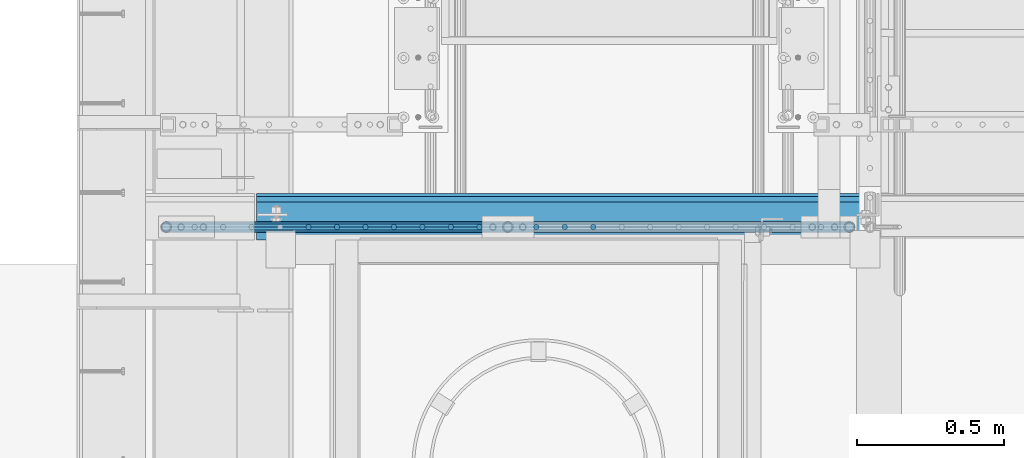
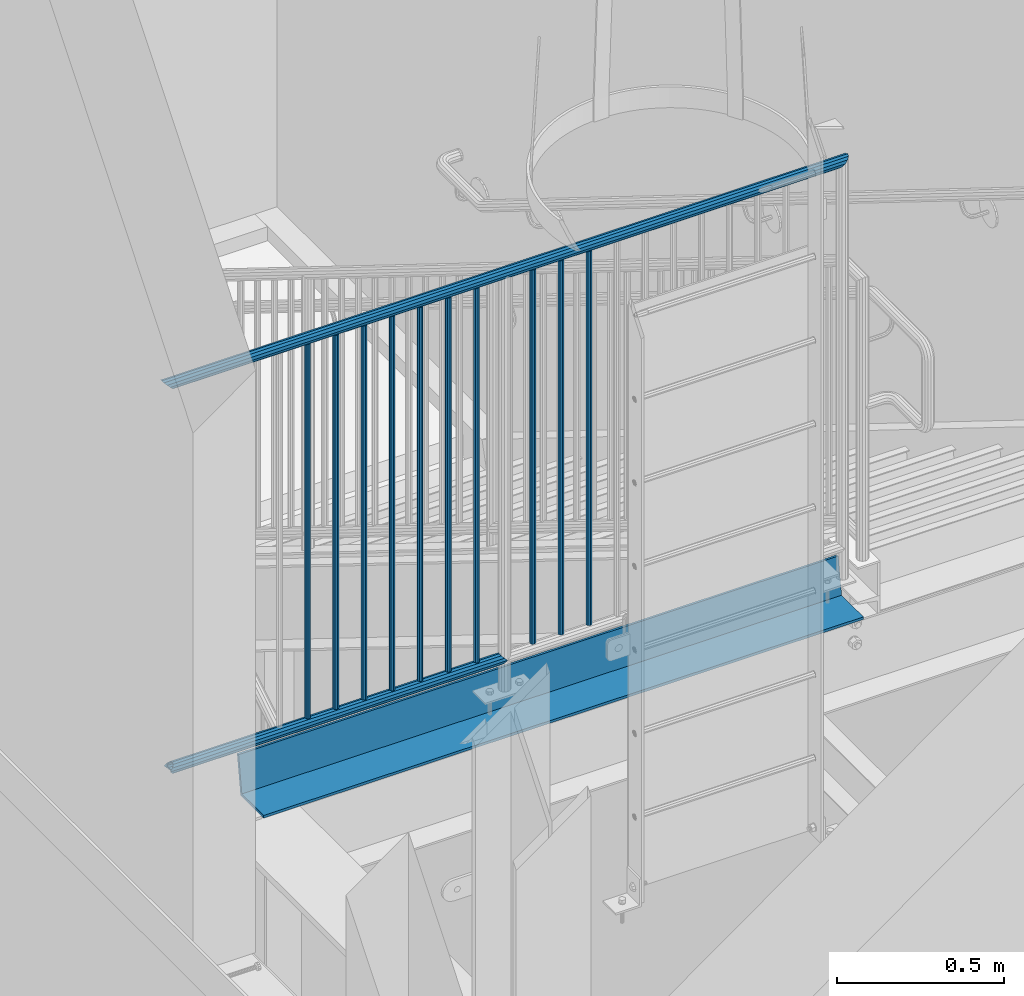
# One storey, part 1083 of 1763: 13 beams, 2 elements without a shape of their own.
"""IFC2X3 building model written with IfcOpenShell, lengths in millimetres."""

from ifc_helpers import new_model, si_unit, frame, origin_with_axes, place, context, subcontext, project, spatial, faceted_brep, material, type_object, element, aggregate, save


model = new_model("IFC2X3")

# Units and contexts
model_context = context("Model", 3, precision=1e-05, world=origin_with_axes())
body_context = subcontext(model_context, "Body", "Model", "MODEL_VIEW")
ifc_project = project(units=[si_unit("LENGTHUNIT", "METRE", prefix="MILLI"), si_unit("AREAUNIT", "SQUARE_METRE"), si_unit("VOLUMEUNIT", "CUBIC_METRE"), si_unit("MASSUNIT", "GRAM", prefix="KILO"), si_unit("TIMEUNIT", "SECOND"), si_unit("PLANEANGLEUNIT", "RADIAN"), si_unit("SOLIDANGLEUNIT", "STERADIAN"), si_unit("THERMODYNAMICTEMPERATUREUNIT", "DEGREE_CELSIUS"), si_unit("LUMINOUSINTENSITYUNIT", "LUMEN")], contexts=[model_context])

# Site, building, storey
site_placement = place(None, origin_with_axes())
site = spatial("IfcSite", under=ifc_project, at=site_placement, CompositionType="ELEMENT")
building_placement = place(site_placement, origin_with_axes())
building = spatial("IfcBuilding", under=site, at=building_placement, Name="Undefined", CompositionType="ELEMENT")
storey_placement = place(building_placement, origin_with_axes())
storey = spatial("IfcBuildingStorey", under=building, at=storey_placement, Name="Undefined", CompositionType="ELEMENT", Elevation=0.0)

# Assembly, beams
assembly_1_placement = place(storey_placement, origin_with_axes())
assembly_1 = element("IfcElementAssembly", 1, at=assembly_1_placement, inside=storey, Name="RAIL", AssemblyPlace="NOTDEFINED", PredefinedType="RIGID_FRAME")
ifc_material_1 = material(Name="STEEL/A513")
beam_type_1 = type_object("IfcBeamType", PredefinedType="NOTDEFINED")
beam_1_placement = place(assembly_1_placement, frame((-86514.9796871242, 31673.8000005342, 5454.64999991884), z_axis=(0.0, 0.0, 1.0), x_axis=(-1.0, 0.0, 0.0)))
beam_1 = element("IfcBeam", 2, at=beam_1_placement, type_object=beam_type_1, material=ifc_material_1, Name="RAIL", context=body_context, shape_type="Brep", body=[
    faceted_brep([(1148.75980258887, -9.52499999949214, 16.4977839420935), (1148.75980258887, -9.52500036633865, 11.4667120131071), (1148.26637405265, -7.68349999948987, 13.3082123799559), (1146.20758653089, 5.74800651520491e-10, 15.3670000000002), (1146.20758653089, 5.74800651520491e-10, 19.0500000000002), (1148.26637424916, 7.6835000005085, 13.3082123799559), (1148.75980258873, 9.52499963366063, 11.4667127468038), (1148.75980258873, 9.52500000051077, 16.4977839420935), (1165.25758657494, 19.0500000005159, 0.0), (1155.73258653076, 16.4977839426028, 9.52499999999964), (1155.73258653076, 16.4977839426028, -9.52499999999964), (1152.54301533551, 13.308212380467, 7.68350000000009), (1154.60180295554, 15.3670000005113, 0.0), (1152.54301533551, 13.308212380467, -7.68350000000009), (1148.75980258873, 9.52499963366063, -11.4667127468038), (1148.75980258873, 9.52500000051077, -16.4977839420935), (1148.26637424916, 7.6835000005085, -13.3082123799559), (1146.20758653089, 5.0931703299284e-10, -15.3670000000002), (1146.20758653089, 5.0931703299284e-10, -19.0500000000002), (1148.75980258887, -9.52500036633865, -11.4667120131071), (1148.75980258887, -9.52499999949214, -16.4977839420935), (1148.26637405265, -7.68349999948987, -13.3082123799559), (1165.25758653104, -19.050000366391, 0.0), (1155.73258653101, -16.4977839415842, -9.52499999999964), (1155.73258653101, -16.4977839415842, 9.52499999999964), (1152.54301460199, -13.3082123794447, -7.68350000000009), (1154.60180222205, -15.3669999994891, 0.0), (1152.54301460199, -13.3082123794447, 7.68350000000009), (9.52499999467545, -16.4977839420899, -9.52500000000009), (16.4977839367712, -9.52499999999418, -16.4977839420935), (0.0, 19.0500000000029, 0.0), (9.52499999467545, 16.4977839420899, -9.52500000000009), (9.52500000096188, 16.4977839420899, 9.52500000000009), (16.4977839430576, 9.52499999999418, 16.4977839420935), (19.0500000009633, 0.0, 19.0500000000002), (16.4977839367712, 9.52499999999418, -16.4977839420935), (19.0499999946769, 0.0, -19.0500000000002), (19.0499999946769, 0.0, -15.3670000000002), (16.4977839367712, -9.52500000031432, -11.4667123796353), (16.9912123747126, -7.68349999999919, -13.3082123799554), (16.9912123745453, 7.68349999999919, -13.3082123799554), (16.4977839367712, 9.52499999967404, -11.4667123802756), (12.7145715564911, 13.3082123799541, -7.68350000000009), (10.6557839364468, 15.3669999999984, 0.0), (12.7145715564911, 13.3082123799541, 7.68350000000009), (16.4977839367712, 9.52499999967404, 11.4667123802756), (16.9912123745453, 7.68349999999919, 13.3082123799554), (19.0499999946769, -3.20142135024071e-10, 15.3670000000002), (16.9912123747126, -7.68349999999919, 13.3082123799554), (16.4977839367712, -9.52500000031432, 11.4667123796353), (16.4977839430576, -9.52499999999418, 16.4977839420935), (9.52500000096188, -16.4977839420899, 9.52500000000009), (0.0, -19.0500000000029, 0.0), (12.7145715571314, -13.3082123799541, 7.68350000000009), (10.6557839370871, -15.3669999999984, 0.0), (12.7145715571314, -13.3082123799541, -7.68350000000009)], [[[0, 1, 2, 3, 4]], [[4, 3, 5, 6, 7]], [[8, 9, 10]], [[7, 6, 11, 12, 13, 14, 15, 10, 9]], [[16, 17, 18, 15, 14]], [[19, 20, 18, 17, 21]], [[22, 23, 24]], [[24, 23, 20, 19, 25, 26, 27, 1, 0]], [[28, 29, 20, 23]], [[30, 31, 32]], [[33, 34, 4, 7]], [[32, 33, 7, 9]], [[30, 32, 9, 8]], [[31, 30, 8, 10]], [[35, 31, 10, 15]], [[36, 35, 15, 18]], [[29, 36, 18, 20]], [[37, 36, 29, 38, 39]], [[40, 41, 35, 36, 37]], [[32, 31, 35, 41, 42, 43, 44, 45, 33]], [[33, 45, 46, 47, 34]], [[34, 47, 48, 49, 50]], [[34, 50, 0, 4]], [[50, 51, 24, 0]], [[51, 52, 22, 24]], [[52, 28, 23, 22]], [[51, 28, 52]], [[50, 49, 53, 54, 55, 38, 29, 28, 51]], [[55, 54, 26, 25]], [[21, 39, 38, 55, 25, 19]], [[37, 39, 21, 17]], [[40, 37, 17, 16]], [[42, 41, 40, 16, 14, 13]], [[43, 42, 13, 12]], [[44, 43, 12, 11]], [[5, 46, 45, 44, 11, 6]], [[47, 46, 5, 3]], [[48, 47, 3, 2]], [[53, 49, 48, 2, 1, 27]], [[54, 53, 27, 26]]]),
])
beam_2_placement = place(assembly_1_placement, frame((-87699.2872736982, 31673.7999995938, 6858.00000000992), z_axis=(0.0, 0.0, -1.0), x_axis=(1.0, 0.0, 0.0)))
beam_2 = element("IfcBeam", 3, at=beam_2_placement, type_object=beam_type_1, material=ifc_material_1, Name="RAIL", context=body_context, shape_type="Brep", body=[
    faceted_brep([(19.0500000000029, -15.3670000000855, 0.0), (26.7334999735467, -13.3082123799541, 7.68350000000009), (2341.881673235, -13.3082123809982, 7.68350000000009), (2349.56517323499, -15.3670000010461, 0.0), (32.3582123535016, -7.68349999999919, 13.3082123799554), (2336.25696085505, -7.68350000103965, 13.3082123799559), (34.4169999735459, 0.0, 15.3670000000002), (2334.19817323504, -1.03682396002114e-09, 15.3670000000002), (32.3582123535016, 7.68349999999919, 13.3082123799554), (2336.25696085511, 7.68349999896236, 13.3082123799559), (26.7334999735467, 13.3082123799541, 7.68350000000009), (2341.88167323508, 13.3082123789136, 7.68350000000009), (19.0500000000029, 15.3669999999146, 0.0), (2349.5651732351, 15.3669999989543, 0.0), (11.3664999735483, 13.3082123799541, -7.68350000000009), (2357.24867323508, 13.3082123789063, -7.68350000000009), (5.74178759359347, 7.68349999999919, -13.3082123799554), (2362.87338561502, 7.68349999894781, -13.3082123799559), (3.68299997354916, 0.0, -15.3670000000002), (2364.93217323505, -1.05137587524951e-09, -15.3670000000002), (5.74178759359347, -7.68349999999919, -13.3082123799554), (2362.87338561498, -7.68350000105056, -13.3082123799559), (11.3664999735483, -13.3082123799541, -7.68350000000009), (2357.24867323501, -13.3082123810054, -7.68350000000009), (19.0500000000029, -19.0500000000854, 0.0), (9.52499999467545, -16.4977839420899, -9.52500000000009), (2359.09017323499, -16.4977839431413, -9.52499999999964), (2349.56517323498, -19.050000001047, 0.0), (2.55221603145037, -9.52499999999418, -16.4977839420935), (2366.06295717711, -9.52500000105283, -16.4977839420935), (1.45519152283669e-11, 1.81898940354586e-12, -19.0499999999993), (2368.61517323504, -1.05137587524951e-09, -19.0500000000002), (2.55221603145037, 9.52499999999418, -16.4977839420935), (2366.06295717717, 9.52499999894644, -16.4977839420935), (9.52499999467545, 16.4977839420899, -9.52500000000009), (2359.0901732351, 16.4977839410458, -9.52499999999964), (19.0500000000029, 19.0499999999146, 0.0), (2349.56517323511, 19.0499999989552, 0.0), (28.574999973549, 16.4977839420899, 9.52500000000009), (2340.0401732351, 16.4977839410531, 9.52499999999964), (35.5477839156374, 9.52499999999418, 16.4977839420935), (2333.06738929298, 9.52499999896099, 16.4977839420935), (38.0999999735432, 0.0, 19.0500000000002), (2330.51517323505, -1.03682396002114e-09, 19.0500000000002), (35.5477839156374, -9.52499999999418, 16.4977839420935), (2333.06738929292, -9.52500000103828, 16.4977839420935), (28.574999973549, -16.4977839420899, 9.52500000000009), (2340.04017323499, -16.497783943134, 9.52499999999964)], [[[0, 1, 2, 3]], [[1, 4, 5, 2]], [[4, 6, 7, 5]], [[6, 8, 9, 7]], [[8, 10, 11, 9]], [[10, 12, 13, 11]], [[12, 14, 15, 13]], [[14, 16, 17, 15]], [[16, 18, 19, 17]], [[18, 20, 21, 19]], [[20, 22, 23, 21]], [[22, 0, 3, 23]], [[24, 25, 26, 27]], [[25, 28, 29, 26]], [[28, 30, 31, 29]], [[30, 32, 33, 31]], [[32, 34, 35, 33]], [[34, 36, 37, 35]], [[36, 38, 39, 37]], [[38, 40, 41, 39]], [[40, 42, 43, 41]], [[42, 44, 45, 43]], [[44, 46, 47, 45]], [[46, 24, 27, 47]], [[29, 31, 33, 35, 37, 39, 41, 43, 45, 47, 27, 26], [5, 7, 9, 11, 13, 15, 17, 19, 21, 23, 3, 2]], [[46, 44, 42, 40, 38, 36, 34, 32, 30, 28, 25, 24], [22, 20, 18, 16, 14, 12, 10, 8, 6, 4, 1, 0]]]),
])
ifc_material_2 = material(Name="STEEL/A36")
beam_type_2 = type_object("IfcBeamType", PredefinedType="NOTDEFINED")
beam_3_placement = place(assembly_1_placement, frame((-87194.7132792923, 31673.7999999813, 6857.99999997406), z_axis=(0.0, -1.0, 0.0), x_axis=(0.0, 0.0, -1.0)))
beam_3 = element("IfcBeam", 4, at=beam_3_placement, type_object=beam_type_2, material=ifc_material_2, Name="PICKET", context=body_context, shape_type="Brep", body=[
    faceted_brep([(19.0499999999092, -9.52500000000146, 0.0), (19.0499999999092, -6.73519209080405, -6.73519209079677), (1384.29999999477, -6.73519209082588, -6.73519209079677), (1384.29999999477, -9.52499999999418, 3.63797880709171e-12), (19.0499999999092, 0.0, -9.52499999999418), (1384.29999999477, -4.36557456851006e-11, -9.52500000000146), (19.0499999999092, 6.73519209080405, -6.73519209079677), (1384.29999999477, 6.73519209078222, -6.73519209080769), (19.0499999999092, 9.52500000000146, 0.0), (1384.29999999477, 9.52499999999418, -3.63797880709171e-12), (19.0499999999092, 6.73519209080405, 6.73519209079677), (1384.29999999477, 6.73519209082588, 6.73519209079677), (19.0499999999092, 0.0, 9.52499999999418), (1384.29999999477, 2.91038304567337e-11, 9.52500000000146), (19.0499999999092, -6.73519209080405, 6.73519209079677), (1384.29999999477, -6.73519209078222, 6.73519209080769)], [[[0, 1, 2, 3]], [[1, 4, 5, 2]], [[4, 6, 7, 5]], [[6, 8, 9, 7]], [[8, 10, 11, 9]], [[10, 12, 13, 11]], [[12, 14, 15, 13]], [[14, 0, 3, 15]], [[5, 7, 9, 11, 13, 15, 3, 2]], [[14, 12, 10, 8, 6, 4, 1, 0]]]),
])
beam_4_placement = place(assembly_1_placement, frame((-87097.6084804111, 31673.8000000588, 6857.99999996617), z_axis=(0.0, -1.0, 0.0), x_axis=(0.0, 0.0, -1.0)))
beam_4 = element("IfcBeam", 5, at=beam_4_placement, type_object=beam_type_2, material=ifc_material_2, Name="PICKET", context=body_context, shape_type="Brep", body=[
    faceted_brep([(19.0499999999092, -9.52500000000146, 0.0), (19.0499999999092, -6.73519209080405, -6.73519209079677), (1384.29999999477, -6.73519209082588, -6.73519209079677), (1384.29999999477, -9.52499999999418, 3.63797880709171e-12), (19.0499999999092, 0.0, -9.52499999999418), (1384.29999999477, -4.36557456851006e-11, -9.52500000000146), (19.0499999999092, 6.73519209080405, -6.73519209079677), (1384.29999999477, 6.73519209078222, -6.73519209080769), (19.0499999999092, 9.52500000000146, 0.0), (1384.29999999477, 9.52499999999418, -3.63797880709171e-12), (19.0499999999092, 6.73519209080405, 6.73519209079677), (1384.29999999477, 6.73519209082588, 6.73519209079677), (19.0499999999092, 0.0, 9.52499999999418), (1384.29999999477, 2.91038304567337e-11, 9.52500000000146), (19.0499999999092, -6.73519209080405, 6.73519209079677), (1384.29999999477, -6.73519209078222, 6.73519209080769)], [[[0, 1, 2, 3]], [[1, 4, 5, 2]], [[4, 6, 7, 5]], [[6, 8, 9, 7]], [[8, 10, 11, 9]], [[10, 12, 13, 11]], [[12, 14, 15, 13]], [[14, 0, 3, 15]], [[5, 7, 9, 11, 13, 15, 3, 2]], [[14, 12, 10, 8, 6, 4, 1, 0]]]),
])
beam_5_placement = place(assembly_1_placement, frame((-87000.5036815298, 31673.8000001364, 6857.99999995828), z_axis=(0.0, -1.0, 0.0), x_axis=(0.0, 0.0, -1.0)))
beam_5 = element("IfcBeam", 6, at=beam_5_placement, type_object=beam_type_2, material=ifc_material_2, Name="PICKET", context=body_context, shape_type="Brep", body=[
    faceted_brep([(19.0499999999092, -9.52500000000146, 0.0), (19.0499999999092, -6.73519209080405, -6.73519209079677), (1384.29999999477, -6.73519209082588, -6.73519209079677), (1384.29999999477, -9.52499999999418, 3.63797880709171e-12), (19.0499999999092, 0.0, -9.52499999999418), (1384.29999999477, -4.36557456851006e-11, -9.52500000000146), (19.0499999999092, 6.73519209080405, -6.73519209079677), (1384.29999999477, 6.73519209078222, -6.73519209080769), (19.0499999999092, 9.52500000000146, 0.0), (1384.29999999477, 9.52499999999418, -3.63797880709171e-12), (19.0499999999092, 6.73519209080405, 6.73519209079677), (1384.29999999477, 6.73519209082588, 6.73519209079677), (19.0499999999092, 0.0, 9.52499999999418), (1384.29999999477, 2.91038304567337e-11, 9.52500000000146), (19.0499999999092, -6.73519209080405, 6.73519209079677), (1384.29999999477, -6.73519209078222, 6.73519209080769)], [[[0, 1, 2, 3]], [[1, 4, 5, 2]], [[4, 6, 7, 5]], [[6, 8, 9, 7]], [[8, 10, 11, 9]], [[10, 12, 13, 11]], [[12, 14, 15, 13]], [[14, 0, 3, 15]], [[5, 7, 9, 11, 13, 15, 3, 2]], [[14, 12, 10, 8, 6, 4, 1, 0]]]),
])
beam_6_placement = place(assembly_1_placement, frame((-86903.3988826486, 31673.8000002139, 6857.99999995039), z_axis=(0.0, -1.0, 0.0), x_axis=(0.0, 0.0, -1.0)))
beam_6 = element("IfcBeam", 7, at=beam_6_placement, type_object=beam_type_2, material=ifc_material_2, Name="PICKET", context=body_context, shape_type="Brep", body=[
    faceted_brep([(19.0499999999092, -9.52500000000146, 0.0), (19.0499999999092, -6.73519209080405, -6.73519209079677), (1384.29999999477, -6.73519209082588, -6.73519209079677), (1384.29999999477, -9.52499999999418, 3.63797880709171e-12), (19.0499999999092, 0.0, -9.52499999999418), (1384.29999999477, -4.36557456851006e-11, -9.52500000000146), (19.0499999999092, 6.73519209080405, -6.73519209079677), (1384.29999999477, 6.73519209078222, -6.73519209080769), (19.0499999999092, 9.52500000000146, 0.0), (1384.29999999477, 9.52499999999418, -3.63797880709171e-12), (19.0499999999092, 6.73519209080405, 6.73519209079677), (1384.29999999477, 6.73519209082588, 6.73519209079677), (19.0499999999092, 0.0, 9.52499999999418), (1384.29999999477, 2.91038304567337e-11, 9.52500000000146), (19.0499999999092, -6.73519209080405, 6.73519209079677), (1384.29999999477, -6.73519209078222, 6.73519209080769)], [[[0, 1, 2, 3]], [[1, 4, 5, 2]], [[4, 6, 7, 5]], [[6, 8, 9, 7]], [[8, 10, 11, 9]], [[10, 12, 13, 11]], [[12, 14, 15, 13]], [[14, 0, 3, 15]], [[5, 7, 9, 11, 13, 15, 3, 2]], [[14, 12, 10, 8, 6, 4, 1, 0]]]),
])
beam_7_placement = place(assembly_1_placement, frame((-86806.2940837673, 31673.8000002914, 6857.9999999425), z_axis=(0.0, -1.0, 0.0), x_axis=(0.0, 0.0, -1.0)))
beam_7 = element("IfcBeam", 8, at=beam_7_placement, type_object=beam_type_2, material=ifc_material_2, Name="PICKET", context=body_context, shape_type="Brep", body=[
    faceted_brep([(19.0499999999092, -9.52500000000146, 0.0), (19.0499999999092, -6.73519209080405, -6.73519209079677), (1384.29999999477, -6.73519209082588, -6.73519209079677), (1384.29999999477, -9.52499999999418, 3.63797880709171e-12), (19.0499999999092, 0.0, -9.52499999999418), (1384.29999999477, -4.36557456851006e-11, -9.52500000000146), (19.0499999999092, 6.73519209080405, -6.73519209079677), (1384.29999999477, 6.73519209078222, -6.73519209080769), (19.0499999999092, 9.52500000000146, 0.0), (1384.29999999477, 9.52499999999418, -3.63797880709171e-12), (19.0499999999092, 6.73519209080405, 6.73519209079677), (1384.29999999477, 6.73519209082588, 6.73519209079677), (19.0499999999092, 0.0, 9.52499999999418), (1384.29999999477, 2.91038304567337e-11, 9.52500000000146), (19.0499999999092, -6.73519209080405, 6.73519209079677), (1384.29999999477, -6.73519209078222, 6.73519209080769)], [[[0, 1, 2, 3]], [[1, 4, 5, 2]], [[4, 6, 7, 5]], [[6, 8, 9, 7]], [[8, 10, 11, 9]], [[10, 12, 13, 11]], [[12, 14, 15, 13]], [[14, 0, 3, 15]], [[5, 7, 9, 11, 13, 15, 3, 2]], [[14, 12, 10, 8, 6, 4, 1, 0]]]),
])
beam_8_placement = place(assembly_1_placement, frame((-86709.1892848861, 31673.800000369, 6857.99999993461), z_axis=(0.0, -1.0, 0.0), x_axis=(0.0, 0.0, -1.0)))
beam_8 = element("IfcBeam", 9, at=beam_8_placement, type_object=beam_type_2, material=ifc_material_2, Name="PICKET", context=body_context, shape_type="Brep", body=[
    faceted_brep([(19.0499999999092, -9.52500000000146, 0.0), (19.0499999999092, -6.73519209080405, -6.73519209079677), (1384.29999999477, -6.73519209082588, -6.73519209079677), (1384.29999999477, -9.52499999999418, 3.63797880709171e-12), (19.0499999999092, 0.0, -9.52499999999418), (1384.29999999477, -4.36557456851006e-11, -9.52500000000146), (19.0499999999092, 6.73519209080405, -6.73519209079677), (1384.29999999477, 6.73519209078222, -6.73519209080769), (19.0499999999092, 9.52500000000146, 0.0), (1384.29999999477, 9.52499999999418, -3.63797880709171e-12), (19.0499999999092, 6.73519209080405, 6.73519209079677), (1384.29999999477, 6.73519209082588, 6.73519209079677), (19.0499999999092, 0.0, 9.52499999999418), (1384.29999999477, 2.91038304567337e-11, 9.52500000000146), (19.0499999999092, -6.73519209080405, 6.73519209079677), (1384.29999999477, -6.73519209078222, 6.73519209080769)], [[[0, 1, 2, 3]], [[1, 4, 5, 2]], [[4, 6, 7, 5]], [[6, 8, 9, 7]], [[8, 10, 11, 9]], [[10, 12, 13, 11]], [[12, 14, 15, 13]], [[14, 0, 3, 15]], [[5, 7, 9, 11, 13, 15, 3, 2]], [[14, 12, 10, 8, 6, 4, 1, 0]]]),
])
beam_9_placement = place(assembly_1_placement, frame((-86612.0844860048, 31673.8000004465, 6857.99999992673), z_axis=(0.0, -1.0, 0.0), x_axis=(0.0, 0.0, -1.0)))
beam_9 = element("IfcBeam", 10, at=beam_9_placement, type_object=beam_type_2, material=ifc_material_2, Name="PICKET", context=body_context, shape_type="Brep", body=[
    faceted_brep([(19.0499999999092, -9.52500000000146, 0.0), (19.0499999999092, -6.73519209080405, -6.73519209079677), (1384.29999999477, -6.73519209082588, -6.73519209079677), (1384.29999999477, -9.52499999999418, 3.63797880709171e-12), (19.0499999999092, 0.0, -9.52499999999418), (1384.29999999477, -4.36557456851006e-11, -9.52500000000146), (19.0499999999092, 6.73519209080405, -6.73519209079677), (1384.29999999477, 6.73519209078222, -6.73519209080769), (19.0499999999092, 9.52500000000146, 0.0), (1384.29999999477, 9.52499999999418, -3.63797880709171e-12), (19.0499999999092, 6.73519209080405, 6.73519209079677), (1384.29999999477, 6.73519209082588, 6.73519209079677), (19.0499999999092, 0.0, 9.52499999999418), (1384.29999999477, 2.91038304567337e-11, 9.52500000000146), (19.0499999999092, -6.73519209080405, 6.73519209079677), (1384.29999999477, -6.73519209078222, 6.73519209080769)], [[[0, 1, 2, 3]], [[1, 4, 5, 2]], [[4, 6, 7, 5]], [[6, 8, 9, 7]], [[8, 10, 11, 9]], [[10, 12, 13, 11]], [[12, 14, 15, 13]], [[14, 0, 3, 15]], [[5, 7, 9, 11, 13, 15, 3, 2]], [[14, 12, 10, 8, 6, 4, 1, 0]]]),
])
beam_10_placement = place(assembly_1_placement, frame((-86417.8748882423, 31673.8000005989, 6857.99999991884), z_axis=(0.0, -1.0, 0.0), x_axis=(0.0, 0.0, -1.0)))
beam_10 = element("IfcBeam", 11, at=beam_10_placement, type_object=beam_type_2, material=ifc_material_2, Name="PICKET", context=body_context, shape_type="Brep", body=[
    faceted_brep([(19.0499999999092, -9.52500000000146, 0.0), (19.0499999999092, -6.73519209080405, -6.73519209079677), (1384.29999999477, -6.73519209082588, -6.73519209079677), (1384.29999999477, -9.52499999999418, 3.63797880709171e-12), (19.0499999999092, 0.0, -9.52499999999418), (1384.29999999477, -4.36557456851006e-11, -9.52500000000146), (19.0499999999092, 6.73519209080405, -6.73519209079677), (1384.29999999477, 6.73519209078222, -6.73519209080769), (19.0499999999092, 9.52500000000146, 0.0), (1384.29999999477, 9.52499999999418, -3.63797880709171e-12), (19.0499999999092, 6.73519209080405, 6.73519209079677), (1384.29999999477, 6.73519209082588, 6.73519209079677), (19.0499999999092, 0.0, 9.52499999999418), (1384.29999999477, 2.91038304567337e-11, 9.52500000000146), (19.0499999999092, -6.73519209080405, 6.73519209079677), (1384.29999999477, -6.73519209078222, 6.73519209080769)], [[[0, 1, 2, 3]], [[1, 4, 5, 2]], [[4, 6, 7, 5]], [[6, 8, 9, 7]], [[8, 10, 11, 9]], [[10, 12, 13, 11]], [[12, 14, 15, 13]], [[14, 0, 3, 15]], [[5, 7, 9, 11, 13, 15, 3, 2]], [[14, 12, 10, 8, 6, 4, 1, 0]]]),
])
beam_11_placement = place(assembly_1_placement, frame((-86320.7700893611, 31673.8000006738, 6857.99999991884), z_axis=(0.0, -1.0, 0.0), x_axis=(0.0, 0.0, -1.0)))
beam_11 = element("IfcBeam", 12, at=beam_11_placement, type_object=beam_type_2, material=ifc_material_2, Name="PICKET", context=body_context, shape_type="Brep", body=[
    faceted_brep([(19.0499999999092, -9.52500000000146, 0.0), (19.0499999999092, -6.73519209080405, -6.73519209079677), (1384.29999999477, -6.73519209082588, -6.73519209079677), (1384.29999999477, -9.52499999999418, 3.63797880709171e-12), (19.0499999999092, 0.0, -9.52499999999418), (1384.29999999477, -4.36557456851006e-11, -9.52500000000146), (19.0499999999092, 6.73519209080405, -6.73519209079677), (1384.29999999477, 6.73519209078222, -6.73519209080769), (19.0499999999092, 9.52500000000146, 0.0), (1384.29999999477, 9.52499999999418, -3.63797880709171e-12), (19.0499999999092, 6.73519209080405, 6.73519209079677), (1384.29999999477, 6.73519209082588, 6.73519209079677), (19.0499999999092, 0.0, 9.52499999999418), (1384.29999999477, 2.91038304567337e-11, 9.52500000000146), (19.0499999999092, -6.73519209080405, 6.73519209079677), (1384.29999999477, -6.73519209078222, 6.73519209080769)], [[[0, 1, 2, 3]], [[1, 4, 5, 2]], [[4, 6, 7, 5]], [[6, 8, 9, 7]], [[8, 10, 11, 9]], [[10, 12, 13, 11]], [[12, 14, 15, 13]], [[14, 0, 3, 15]], [[5, 7, 9, 11, 13, 15, 3, 2]], [[14, 12, 10, 8, 6, 4, 1, 0]]]),
])
beam_12_placement = place(assembly_1_placement, frame((-86223.6652904798, 31673.8000007487, 6857.99999991884), z_axis=(0.0, -1.0, 0.0), x_axis=(0.0, 0.0, -1.0)))
beam_12 = element("IfcBeam", 13, at=beam_12_placement, type_object=beam_type_2, material=ifc_material_2, Name="PICKET", context=body_context, shape_type="Brep", body=[
    faceted_brep([(19.0499999999092, -9.52500000000146, 0.0), (19.0499999999092, -6.73519209080405, -6.73519209079677), (1384.29999999477, -6.73519209082588, -6.73519209079677), (1384.29999999477, -9.52499999999418, 3.63797880709171e-12), (19.0499999999092, 0.0, -9.52499999999418), (1384.29999999477, -4.36557456851006e-11, -9.52500000000146), (19.0499999999092, 6.73519209080405, -6.73519209079677), (1384.29999999477, 6.73519209078222, -6.73519209080769), (19.0499999999092, 9.52500000000146, 0.0), (1384.29999999477, 9.52499999999418, -3.63797880709171e-12), (19.0499999999092, 6.73519209080405, 6.73519209079677), (1384.29999999477, 6.73519209082588, 6.73519209079677), (19.0499999999092, 0.0, 9.52499999999418), (1384.29999999477, 2.91038304567337e-11, 9.52500000000146), (19.0499999999092, -6.73519209080405, 6.73519209079677), (1384.29999999477, -6.73519209078222, 6.73519209080769)], [[[0, 1, 2, 3]], [[1, 4, 5, 2]], [[4, 6, 7, 5]], [[6, 8, 9, 7]], [[8, 10, 11, 9]], [[10, 12, 13, 11]], [[12, 14, 15, 13]], [[14, 0, 3, 15]], [[5, 7, 9, 11, 13, 15, 3, 2]], [[14, 12, 10, 8, 6, 4, 1, 0]]]),
])
aggregate(assembly_1, [beam_3, beam_4, beam_5, beam_6, beam_7, beam_8, beam_9, beam_10, beam_11, beam_12, beam_1, beam_2])

# Assembly, beam
assembly_2_placement = place(storey_placement, origin_with_axes())
assembly_2 = element("IfcElementAssembly", 14, at=assembly_2_placement, inside=storey, Name="CHANNEL", AssemblyPlace="NOTDEFINED", PredefinedType="RIGID_FRAME")
beam_type_3 = type_object("IfcBeamType", PredefinedType="NOTDEFINED")
beam_13_placement = place(assembly_2_placement, frame((-86337.2122736983, 31629.3500001343, 5199.06250001302), z_axis=(-1.0, 0.0, 0.0), x_axis=(0.0, 1.0, 0.0)))
beam_13 = element("IfcBeam", 15, at=beam_13_placement, type_object=beam_type_3, material=ifc_material_2, Name="TREAD", context=body_context, shape_type="Brep", body=[
    faceted_brep([(-3.63797880709171e-12, -4.76249999999982, -1035.05), (-3.63797880709171e-12, -4.76249999999982, 1035.05), (3.63797880709171e-12, 4.76249999999982, 1035.05), (3.63797880709171e-12, 4.76249999999982, -1035.05), (138.293624877937, 4.76249999994434, 1035.05), (138.293624877937, 4.76249999994434, -1035.05), (130.061802011536, -4.76250000005257, -1035.05), (130.061802011536, -4.76250000005257, 1035.05), (158.750000000007, -134.93749694824, 1035.05), (158.750000000007, -134.93749694824, -1035.05), (149.325503959786, -136.317532957881, 1035.05), (149.325503959786, -136.317532957881, -1035.05)], [[[0, 1, 2, 3]], [[3, 2, 4, 5]], [[1, 0, 6, 7]], [[5, 4, 8, 9]], [[4, 2, 1, 7, 10, 8]], [[7, 6, 11, 10]], [[6, 0, 3, 5, 9, 11]], [[10, 11, 9, 8]]]),
])
aggregate(assembly_2, [beam_13])

save(model, "model.ifc")
